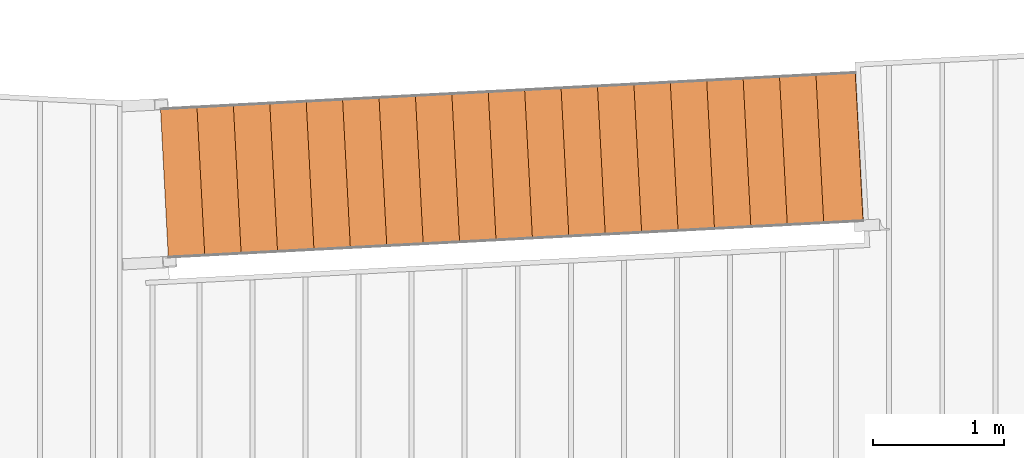
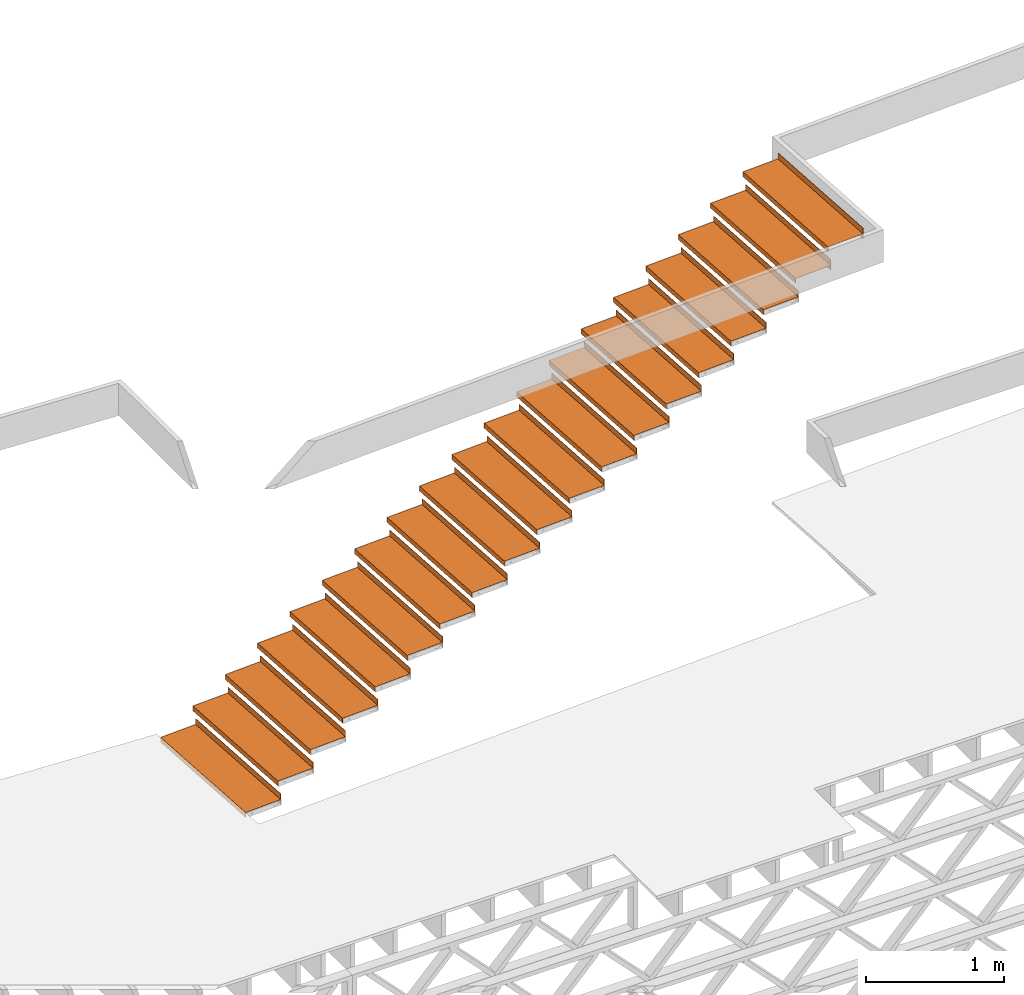
# One storey, part 14 of 23: 19 proxies.
"""IFC4 building model written with IfcOpenShell, lengths in feet."""

from ifc_helpers import new_model, entity, si_unit, converted_unit, derived_unit, direction, frame, origin, place, context, subcontext, project, spatial, polyline, outline, extrude, source, transform, mapped, material, type_object, type_shapes, element, save


model = new_model("IFC4")

# Units and contexts
model_context = context("Model", 3, precision=0.0001, world=origin(), true_north=direction((6.12303176911189e-17, 1.0)))
body_context = subcontext(model_context, "Body", "Model", "MODEL_VIEW")
ifc_project = project(units=[converted_unit("LENGTHUNIT", "FOOT", entity("IfcRatioMeasure", 0.3048), si_unit("LENGTHUNIT", "METRE"), dimensions=[1, 0, 0, 0, 0, 0, 0]), converted_unit("AREAUNIT", "SQUARE FOOT", entity("IfcRatioMeasure", 0.09290304), si_unit("AREAUNIT", "SQUARE_METRE"), dimensions=[2, 0, 0, 0, 0, 0, 0]), converted_unit("VOLUMEUNIT", "CUBIC FOOT", entity("IfcRatioMeasure", 0.028316846592), si_unit("VOLUMEUNIT", "CUBIC_METRE"), dimensions=[3, 0, 0, 0, 0, 0, 0]), converted_unit("PLANEANGLEUNIT", "DEGREE", entity("IfcRatioMeasure", 0.0174532925199433), si_unit("PLANEANGLEUNIT", "RADIAN"), dimensions=[0, 0, 0, 0, 0, 0, 0]), si_unit("MASSUNIT", "GRAM", prefix="KILO"), derived_unit("MASSDENSITYUNIT", [(si_unit("MASSUNIT", "GRAM", prefix="KILO"), 1), (si_unit("LENGTHUNIT", "METRE"), -3)]), derived_unit("MOMENTOFINERTIAUNIT", [(si_unit("LENGTHUNIT", "METRE"), 4)]), si_unit("TIMEUNIT", "SECOND"), si_unit("FREQUENCYUNIT", "HERTZ"), si_unit("THERMODYNAMICTEMPERATUREUNIT", "DEGREE_CELSIUS"), derived_unit("THERMALTRANSMITTANCEUNIT", [(si_unit("MASSUNIT", "GRAM", prefix="KILO"), 1), (si_unit("THERMODYNAMICTEMPERATUREUNIT", "KELVIN"), -1), (si_unit("TIMEUNIT", "SECOND"), -3)]), derived_unit("VOLUMETRICFLOWRATEUNIT", [(si_unit("LENGTHUNIT", "METRE"), 3), (si_unit("TIMEUNIT", "SECOND"), -1)]), si_unit("ELECTRICCURRENTUNIT", "AMPERE"), si_unit("ELECTRICVOLTAGEUNIT", "VOLT"), si_unit("POWERUNIT", "WATT"), si_unit("FORCEUNIT", "NEWTON"), si_unit("ILLUMINANCEUNIT", "LUX"), si_unit("LUMINOUSFLUXUNIT", "LUMEN"), si_unit("LUMINOUSINTENSITYUNIT", "CANDELA"), derived_unit("USERDEFINED", [(si_unit("MASSUNIT", "GRAM", prefix="KILO"), -1), (si_unit("LENGTHUNIT", "METRE"), -2), (si_unit("TIMEUNIT", "SECOND"), 3), (si_unit("LUMINOUSFLUXUNIT", "LUMEN"), 1)]), derived_unit("LINEARVELOCITYUNIT", [(si_unit("LENGTHUNIT", "METRE"), 1), (si_unit("TIMEUNIT", "SECOND"), -1)]), si_unit("PRESSUREUNIT", "PASCAL"), derived_unit("USERDEFINED", [(si_unit("LENGTHUNIT", "METRE"), -2), (si_unit("MASSUNIT", "GRAM", prefix="KILO"), 1), (si_unit("TIMEUNIT", "SECOND"), -2)]), derived_unit("LINEARFORCEUNIT", [(si_unit("MASSUNIT", "GRAM", prefix="KILO"), 1), (si_unit("LENGTHUNIT", "METRE"), 1), (si_unit("TIMEUNIT", "SECOND"), -2), (si_unit("LENGTHUNIT", "METRE"), -1)]), derived_unit("PLANARFORCEUNIT", [(si_unit("MASSUNIT", "GRAM", prefix="KILO"), 1), (si_unit("LENGTHUNIT", "METRE"), 1), (si_unit("TIMEUNIT", "SECOND"), -2), (si_unit("LENGTHUNIT", "METRE"), -2)])], contexts=[model_context])

# Site, building, storey
site_placement = place(None, origin())
site = spatial("IfcSite", under=ifc_project, at=site_placement, CompositionType="ELEMENT")
building_placement = place(site_placement, origin())
building = spatial("IfcBuilding", under=site, at=building_placement, CompositionType="ELEMENT")
storey_placement = place(building_placement, frame((0.0, 0.0, 10.8020833333333)))
storey = spatial("IfcBuildingStorey", under=building, at=storey_placement, Name="2ND FLOOR", CompositionType="ELEMENT", Elevation=10.8020833333333)

# Proxies
ifc_material = material(Name="GALV. STEEL TREAD", Category="Materials")
building_element_proxy_type_1 = type_object("IfcBuildingElementProxyType", Name="Generic Models 889:Generic Models 629", PredefinedType="NOTDEFINED", material=ifc_material)
shared_shape_1 = source(origin(), body_context, "Body", "SweptSolid", [
    extrude(outline(polyline([(-0.597916666666609, 0.02708333333333), (-0.597916666666598, -0.118750000000006), (-0.587499999999985, -0.118750000000006), (-0.587499999999975, 0.0166666666666657), (0.391666666666639, 0.0166666666666657), (0.39166666666665, -0.118750000000006), (0.402083333333319, -0.118750000000006), (0.40208333333334, 0.193750000000001), (0.391666666666621, 0.193750000000001), (0.391666666666639, 0.02708333333333), (-0.597916666666609, 0.02708333333333)])), frame((0.791176413725196, 0.0312925405038413, 0.118750000000006), z_axis=(0.0523359562429694, -0.998629534754573, 0.0), x_axis=(0.998629534754573, 0.0523359562429694, 0.0)), (0.0, 0.0, -1.0), 3.70833333337879),
])
type_shapes(building_element_proxy_type_1, [shared_shape_1])
proxy_1_placement = place(storey_placement, frame((-229.796644235969, 965.360707740668, 6.41392543859246)))
element("IfcBuildingElementProxy", 1, at=proxy_1_placement, inside=storey, type_object=building_element_proxy_type_1, material=ifc_material, Name="Generic Models 889:Generic Models 629", ObjectType="Generic Models 889:Generic Models 629", PredefinedType="NOTDEFINED", context=body_context, shape_type="MappedRepresentation", body=[
    mapped(shared_shape_1, transform((0.0, 0.0, 0.0), scale=1.0)),
])
building_element_proxy_type_2 = type_object("IfcBuildingElementProxyType", Name="Generic Models 891:Generic Models 629", PredefinedType="NOTDEFINED", material=ifc_material)
shared_shape_2 = source(origin(), body_context, "Body", "SweptSolid", [
    extrude(outline(polyline([(-0.597916666666609, 0.02708333333333), (-0.597916666666598, -0.118750000000006), (-0.587499999999957, -0.118750000000006), (-0.587499999999975, 0.0166666666666657), (0.391666666666639, 0.0166666666666657), (0.39166666666665, -0.118750000000006), (0.402083333333348, -0.118750000000006), (0.40208333333334, 0.193750000000001), (0.391666666666621, 0.193750000000001), (0.391666666666639, 0.02708333333333), (-0.597916666666609, 0.02708333333333)])), frame((0.791176413725196, 0.0312925405037277, 0.118750000000006), z_axis=(0.0523359562429694, -0.998629534754573, 0.0), x_axis=(0.998629534754573, 0.0523359562429694, 0.0)), (0.0, 0.0, -1.0), 3.70833333337879),
])
type_shapes(building_element_proxy_type_2, [shared_shape_2])
proxy_2_placement = place(storey_placement, frame((-224.307413781718, 965.648386118748, 9.7823464912242)))
element("IfcBuildingElementProxy", 2, at=proxy_2_placement, inside=storey, type_object=building_element_proxy_type_2, material=ifc_material, Name="Generic Models 891:Generic Models 629", ObjectType="Generic Models 891:Generic Models 629", PredefinedType="NOTDEFINED", context=body_context, shape_type="MappedRepresentation", body=[
    mapped(shared_shape_2, transform((0.0, 0.0, 0.0), scale=1.0)),
])
building_element_proxy_type_3 = type_object("IfcBuildingElementProxyType", Name="Generic Models 893:Generic Models 629", PredefinedType="NOTDEFINED", material=ifc_material)
shared_shape_3 = source(origin(), body_context, "Body", "SweptSolid", [
    extrude(outline(polyline([(-0.597916666666609, 0.02708333333333), (-0.597916666666598, -0.118750000000006), (-0.587499999999985, -0.118750000000006), (-0.587499999999975, 0.0166666666666657), (0.391666666666639, 0.0166666666666657), (0.39166666666665, -0.118750000000006), (0.402083333333319, -0.118750000000006), (0.40208333333334, 0.193750000000001), (0.391666666666621, 0.193750000000001), (0.391666666666639, 0.02708333333333), (-0.597916666666609, 0.02708333333333)])), frame((0.791176413725196, 0.031292540503955, 0.118750000000006), z_axis=(0.0523359562429694, -0.998629534754573, 0.0), x_axis=(0.998629534754573, 0.0523359562429694, 0.0)), (0.0, 0.0, -1.0), 3.70833333337879),
])
type_shapes(building_element_proxy_type_3, [shared_shape_3])
proxy_3_placement = place(storey_placement, frame((-225.222285524093, 965.600439722401, 9.22094298245225)))
element("IfcBuildingElementProxy", 3, at=proxy_3_placement, inside=storey, type_object=building_element_proxy_type_3, material=ifc_material, Name="Generic Models 893:Generic Models 629", ObjectType="Generic Models 893:Generic Models 629", PredefinedType="NOTDEFINED", context=body_context, shape_type="MappedRepresentation", body=[
    mapped(shared_shape_3, transform((0.0, 0.0, 0.0), scale=1.0)),
])
building_element_proxy_type_4 = type_object("IfcBuildingElementProxyType", Name="Generic Models 895:Generic Models 629", PredefinedType="NOTDEFINED", material=ifc_material)
shared_shape_4 = source(origin(), body_context, "Body", "SweptSolid", [
    extrude(outline(polyline([(-0.597916666666609, 0.0270833333333336), (-0.597916666666598, -0.118750000000002), (-0.587499999999957, -0.118750000000002), (-0.587499999999975, 0.0166666666666693), (0.391666666666639, 0.0166666666666693), (0.39166666666665, -0.118750000000002), (0.402083333333348, -0.118750000000002), (0.40208333333334, 0.193750000000005), (0.391666666666621, 0.193750000000005), (0.391666666666639, 0.0270833333333336), (-0.597916666666609, 0.0270833333333336)])), frame((0.791176413725196, 0.0312925405037277, 0.118750000000002), z_axis=(0.0523359562429694, -0.998629534754573, 0.0), x_axis=(0.998629534754573, 0.0523359562429694, 0.0)), (0.0, 0.0, -1.0), 3.70833333337879),
])
type_shapes(building_element_proxy_type_4, [shared_shape_4])
proxy_4_placement = place(storey_placement, frame((-226.137157266468, 965.552493326055, 8.65953947368029)))
element("IfcBuildingElementProxy", 4, at=proxy_4_placement, inside=storey, type_object=building_element_proxy_type_4, material=ifc_material, Name="Generic Models 895:Generic Models 629", ObjectType="Generic Models 895:Generic Models 629", PredefinedType="NOTDEFINED", context=body_context, shape_type="MappedRepresentation", body=[
    mapped(shared_shape_4, transform((0.0, 0.0, 0.0), scale=1.0)),
])
building_element_proxy_type_5 = type_object("IfcBuildingElementProxyType", Name="Generic Models 897:Generic Models 629", PredefinedType="NOTDEFINED", material=ifc_material)
shared_shape_5 = source(origin(), body_context, "Body", "SweptSolid", [
    extrude(outline(polyline([(-0.597916666666609, 0.0270833333333336), (-0.597916666666598, -0.118750000000002), (-0.587499999999957, -0.118750000000002), (-0.587499999999975, 0.0166666666666693), (0.391666666666639, 0.0166666666666693), (0.39166666666665, -0.118750000000002), (0.402083333333348, -0.118750000000002), (0.40208333333334, 0.193750000000005), (0.391666666666621, 0.193750000000005), (0.391666666666639, 0.0270833333333336), (-0.597916666666609, 0.0270833333333336)])), frame((0.791176413725196, 0.0312925405037277, 0.118750000000002), z_axis=(0.0523359562429694, -0.998629534754573, 0.0), x_axis=(0.998629534754573, 0.0523359562429694, 0.0)), (0.0, 0.0, -1.0), 3.70833333337879),
])
type_shapes(building_element_proxy_type_5, [shared_shape_5])
proxy_5_placement = place(storey_placement, frame((-227.052029008843, 965.504546929708, 8.09813596490834)))
element("IfcBuildingElementProxy", 5, at=proxy_5_placement, inside=storey, type_object=building_element_proxy_type_5, material=ifc_material, Name="Generic Models 897:Generic Models 629", ObjectType="Generic Models 897:Generic Models 629", PredefinedType="NOTDEFINED", context=body_context, shape_type="MappedRepresentation", body=[
    mapped(shared_shape_5, transform((0.0, 0.0, 0.0), scale=1.0)),
])
building_element_proxy_type_6 = type_object("IfcBuildingElementProxyType", Name="Generic Models 899:Generic Models 629", PredefinedType="NOTDEFINED", material=ifc_material)
shared_shape_6 = source(origin(), body_context, "Body", "SweptSolid", [
    extrude(outline(polyline([(-0.597916666666609, 0.0270833333333336), (-0.597916666666598, -0.118750000000002), (-0.587499999999957, -0.118750000000002), (-0.587499999999975, 0.0166666666666693), (0.391666666666639, 0.0166666666666693), (0.39166666666665, -0.118750000000002), (0.402083333333348, -0.118750000000002), (0.40208333333334, 0.193750000000005), (0.391666666666621, 0.193750000000005), (0.391666666666639, 0.0270833333333336), (-0.597916666666609, 0.0270833333333336)])), frame((0.791176413725196, 0.031292540503614, 0.118750000000002), z_axis=(0.0523359562429694, -0.998629534754573, 0.0), x_axis=(0.998629534754573, 0.0523359562429694, 0.0)), (0.0, 0.0, -1.0), 3.70833333337879),
])
type_shapes(building_element_proxy_type_6, [shared_shape_6])
proxy_6_placement = place(storey_placement, frame((-227.966900751219, 965.456600533361, 7.53673245613638)))
element("IfcBuildingElementProxy", 6, at=proxy_6_placement, inside=storey, type_object=building_element_proxy_type_6, material=ifc_material, Name="Generic Models 899:Generic Models 629", ObjectType="Generic Models 899:Generic Models 629", PredefinedType="NOTDEFINED", context=body_context, shape_type="MappedRepresentation", body=[
    mapped(shared_shape_6, transform((0.0, 0.0, 0.0), scale=1.0)),
])
building_element_proxy_type_7 = type_object("IfcBuildingElementProxyType", Name="Generic Models 901:Generic Models 629", PredefinedType="NOTDEFINED", material=ifc_material)
shared_shape_7 = source(origin(), body_context, "Body", "SweptSolid", [
    extrude(outline(polyline([(-0.597916666666609, 0.0270833333333336), (-0.597916666666598, -0.118750000000002), (-0.587499999999957, -0.118750000000002), (-0.587499999999975, 0.0166666666666693), (0.391666666666639, 0.0166666666666693), (0.39166666666665, -0.118750000000002), (0.402083333333348, -0.118750000000002), (0.40208333333334, 0.193750000000005), (0.391666666666621, 0.193750000000005), (0.391666666666639, 0.0270833333333336), (-0.597916666666609, 0.0270833333333336)])), frame((0.791176413725196, 0.0312925405038413, 0.118750000000006), z_axis=(0.0523359562429694, -0.998629534754573, 0.0), x_axis=(0.998629534754573, 0.0523359562429694, 0.0)), (0.0, 0.0, -1.0), 3.70833333337879),
])
type_shapes(building_element_proxy_type_7, [shared_shape_7])
proxy_7_placement = place(storey_placement, frame((-228.881772493594, 965.408654137015, 6.97532894736442)))
element("IfcBuildingElementProxy", 7, at=proxy_7_placement, inside=storey, type_object=building_element_proxy_type_7, material=ifc_material, Name="Generic Models 901:Generic Models 629", ObjectType="Generic Models 901:Generic Models 629", PredefinedType="NOTDEFINED", context=body_context, shape_type="MappedRepresentation", body=[
    mapped(shared_shape_7, transform((0.0, 0.0, 0.0), scale=1.0)),
])
building_element_proxy_type_8 = type_object("IfcBuildingElementProxyType", Name="Generic Models 903:Generic Models 629", PredefinedType="NOTDEFINED", material=ifc_material)
shared_shape_8 = source(origin(), body_context, "Body", "SweptSolid", [
    extrude(outline(polyline([(-0.597916666666553, 0.0270833333333336), (-0.597916666666541, -0.118750000000002), (-0.5874999999999, -0.118750000000002), (-0.587499999999918, 0.0166666666666693), (0.391666666666695, 0.0166666666666693), (0.391666666666707, -0.118750000000002), (0.402083333333404, -0.118750000000002), (0.402083333333397, 0.193750000000005), (0.391666666666677, 0.193750000000005), (0.391666666666695, 0.0270833333333336), (-0.597916666666553, 0.0270833333333336)])), frame((0.79117641372514, 0.0312925405037277, 0.118750000000006), z_axis=(0.0523359562429694, -0.998629534754573, 0.0), x_axis=(0.998629534754573, 0.0523359562429694, 0.0)), (0.0, 0.0, -1.0), 3.70833333337879),
])
type_shapes(building_element_proxy_type_8, [shared_shape_8])
proxy_8_placement = place(storey_placement, frame((-230.711515978344, 965.312761344321, 5.8525219298205)))
element("IfcBuildingElementProxy", 8, at=proxy_8_placement, inside=storey, type_object=building_element_proxy_type_8, material=ifc_material, Name="Generic Models 903:Generic Models 629", ObjectType="Generic Models 903:Generic Models 629", PredefinedType="NOTDEFINED", context=body_context, shape_type="MappedRepresentation", body=[
    mapped(shared_shape_8, transform((0.0, 0.0, 0.0), scale=1.0)),
])
building_element_proxy_type_9 = type_object("IfcBuildingElementProxyType", Name="Generic Models 905:Generic Models 629", PredefinedType="NOTDEFINED", material=ifc_material)
shared_shape_9 = source(origin(), body_context, "Body", "SweptSolid", [
    extrude(outline(polyline([(-0.597916666666609, 0.0270833333333336), (-0.597916666666598, -0.118750000000002), (-0.587499999999957, -0.118750000000002), (-0.587499999999975, 0.0166666666666693), (0.391666666666639, 0.0166666666666693), (0.39166666666665, -0.118750000000002), (0.402083333333348, -0.118750000000002), (0.40208333333334, 0.193750000000005), (0.391666666666621, 0.193750000000005), (0.391666666666639, 0.0270833333333336), (-0.597916666666609, 0.0270833333333336)])), frame((0.791176413725196, 0.0312925405037277, 0.118750000000002), z_axis=(0.0523359562429694, -0.998629534754573, 0.0), x_axis=(0.998629534754573, 0.0523359562429694, 0.0)), (0.0, 0.0, -1.0), 3.70833333337879),
])
type_shapes(building_element_proxy_type_9, [shared_shape_9])
proxy_9_placement = place(storey_placement, frame((-231.626387720719, 965.264814947975, 5.29111842104855)))
element("IfcBuildingElementProxy", 9, at=proxy_9_placement, inside=storey, type_object=building_element_proxy_type_9, material=ifc_material, Name="Generic Models 905:Generic Models 629", ObjectType="Generic Models 905:Generic Models 629", PredefinedType="NOTDEFINED", context=body_context, shape_type="MappedRepresentation", body=[
    mapped(shared_shape_9, transform((0.0, 0.0, 0.0), scale=1.0)),
])
building_element_proxy_type_10 = type_object("IfcBuildingElementProxyType", Name="Generic Models 907:Generic Models 629", PredefinedType="NOTDEFINED", material=ifc_material)
shared_shape_10 = source(origin(), body_context, "Body", "SweptSolid", [
    extrude(outline(polyline([(-0.597916666666609, 0.0270833333333318), (-0.597916666666598, -0.118750000000004), (-0.587499999999957, -0.118750000000004), (-0.587499999999975, 0.0166666666666675), (0.391666666666639, 0.0166666666666675), (0.39166666666665, -0.118750000000004), (0.402083333333348, -0.118750000000004), (0.40208333333334, 0.193750000000003), (0.391666666666621, 0.193750000000003), (0.391666666666639, 0.0270833333333318), (-0.597916666666609, 0.0270833333333318)])), frame((0.791176413725196, 0.0312925405037277, 0.118750000000002), z_axis=(0.0523359562429694, -0.998629534754573, 0.0), x_axis=(0.998629534754573, 0.0523359562429694, 0.0)), (0.0, 0.0, -1.0), 3.70833333337879),
])
type_shapes(building_element_proxy_type_10, [shared_shape_10])
proxy_10_placement = place(storey_placement, frame((-232.541259463095, 965.216868551628, 4.7297149122766)))
element("IfcBuildingElementProxy", 10, at=proxy_10_placement, inside=storey, type_object=building_element_proxy_type_10, material=ifc_material, Name="Generic Models 907:Generic Models 629", ObjectType="Generic Models 907:Generic Models 629", PredefinedType="NOTDEFINED", context=body_context, shape_type="MappedRepresentation", body=[
    mapped(shared_shape_10, transform((0.0, 0.0, 0.0), scale=1.0)),
])
building_element_proxy_type_11 = type_object("IfcBuildingElementProxyType", Name="Generic Models 909:Generic Models 629", PredefinedType="NOTDEFINED", material=ifc_material)
shared_shape_11 = source(origin(), body_context, "Body", "SweptSolid", [
    extrude(outline(polyline([(-0.597916666666609, 0.0270833333333318), (-0.597916666666598, -0.118750000000004), (-0.587499999999957, -0.118750000000004), (-0.587499999999975, 0.0166666666666675), (0.391666666666639, 0.0166666666666675), (0.39166666666665, -0.118750000000004), (0.402083333333348, -0.118750000000004), (0.40208333333334, 0.193750000000003), (0.391666666666621, 0.193750000000003), (0.391666666666639, 0.0270833333333318), (-0.597916666666609, 0.0270833333333318)])), frame((0.791176413725196, 0.0312925405037277, 0.118750000000002), z_axis=(0.0523359562429694, -0.998629534754573, 0.0), x_axis=(0.998629534754573, 0.0523359562429694, 0.0)), (0.0, 0.0, -1.0), 3.70833333337879),
])
type_shapes(building_element_proxy_type_11, [shared_shape_11])
proxy_11_placement = place(storey_placement, frame((-233.45613120547, 965.168922155281, 4.16831140350464)))
element("IfcBuildingElementProxy", 11, at=proxy_11_placement, inside=storey, type_object=building_element_proxy_type_11, material=ifc_material, Name="Generic Models 909:Generic Models 629", ObjectType="Generic Models 909:Generic Models 629", PredefinedType="NOTDEFINED", context=body_context, shape_type="MappedRepresentation", body=[
    mapped(shared_shape_11, transform((0.0, 0.0, 0.0), scale=1.0)),
])
building_element_proxy_type_12 = type_object("IfcBuildingElementProxyType", Name="Generic Models 965:Generic Models 629", PredefinedType="NOTDEFINED", material=ifc_material)
shared_shape_12 = source(origin(), body_context, "Body", "SweptSolid", [
    extrude(outline(polyline([(-0.597916666666553, 0.0270833333333336), (-0.597916666666541, -0.118750000000002), (-0.587499999999929, -0.118750000000002), (-0.587499999999918, 0.0166666666666693), (0.391666666666695, 0.0166666666666693), (0.391666666666707, -0.118750000000002), (0.402083333333376, -0.118750000000002), (0.402083333333397, 0.193750000000005), (0.391666666666677, 0.193750000000005), (0.391666666666695, 0.0270833333333336), (-0.597916666666553, 0.0270833333333336)])), frame((0.79117641372514, 0.031292540503955, 0.11875), z_axis=(0.0523359562429694, -0.998629534754573, 0.0), x_axis=(0.998629534754573, 0.0523359562429694, 0.0)), (0.0, 0.0, -1.0), 3.70833333337879),
])
type_shapes(building_element_proxy_type_12, [shared_shape_12])
proxy_12_placement = place(storey_placement, frame((-234.371002947845, 965.120975758934, 3.60690789473269)))
element("IfcBuildingElementProxy", 12, at=proxy_12_placement, inside=storey, type_object=building_element_proxy_type_12, material=ifc_material, Name="Generic Models 965:Generic Models 629", ObjectType="Generic Models 965:Generic Models 629", PredefinedType="NOTDEFINED", context=body_context, shape_type="MappedRepresentation", body=[
    mapped(shared_shape_12, transform((0.0, 0.0, 0.0), scale=1.0)),
])
building_element_proxy_type_13 = type_object("IfcBuildingElementProxyType", Name="Generic Models 911:Generic Models 629", PredefinedType="NOTDEFINED", material=ifc_material)
shared_shape_13 = source(origin(), body_context, "Body", "SweptSolid", [
    extrude(outline(polyline([(-0.597916666666609, 0.0270833333333318), (-0.597916666666598, -0.118750000000004), (-0.587499999999957, -0.118750000000004), (-0.587499999999975, 0.0166666666666675), (0.391666666666639, 0.0166666666666675), (0.39166666666665, -0.118750000000004), (0.402083333333348, -0.118750000000004), (0.40208333333334, 0.193750000000003), (0.391666666666621, 0.193750000000003), (0.391666666666639, 0.0270833333333318), (-0.597916666666609, 0.0270833333333318)])), frame((0.791176413725196, 0.031292540503614, 0.118750000000002), z_axis=(0.0523359562429694, -0.998629534754573, 0.0), x_axis=(0.998629534754573, 0.0523359562429694, 0.0)), (0.0, 0.0, -1.0), 3.70833333337879),
])
type_shapes(building_element_proxy_type_13, [shared_shape_13])
proxy_13_placement = place(storey_placement, frame((-235.28587469022, 965.073029362588, 3.04550438596073)))
element("IfcBuildingElementProxy", 13, at=proxy_13_placement, inside=storey, type_object=building_element_proxy_type_13, material=ifc_material, Name="Generic Models 911:Generic Models 629", ObjectType="Generic Models 911:Generic Models 629", PredefinedType="NOTDEFINED", context=body_context, shape_type="MappedRepresentation", body=[
    mapped(shared_shape_13, transform((0.0, 0.0, 0.0), scale=1.0)),
])
building_element_proxy_type_14 = type_object("IfcBuildingElementProxyType", Name="Generic Models 913:Generic Models 629", PredefinedType="NOTDEFINED", material=ifc_material)
shared_shape_14 = source(origin(), body_context, "Body", "SweptSolid", [
    extrude(outline(polyline([(-0.597916666666609, 0.0270833333333353), (-0.597916666666598, -0.11875), (-0.587499999999957, -0.11875), (-0.587499999999975, 0.016666666666671), (0.391666666666639, 0.016666666666671), (0.39166666666665, -0.11875), (0.402083333333348, -0.11875), (0.40208333333334, 0.193750000000007), (0.391666666666621, 0.193750000000007), (0.391666666666639, 0.0270833333333353), (-0.597916666666609, 0.0270833333333353)])), frame((0.791176413725196, 0.0312925405038413, 0.118749999999999), z_axis=(0.0523359562429694, -0.998629534754573, 0.0), x_axis=(0.998629534754573, 0.0523359562429694, 0.0)), (0.0, 0.0, -1.0), 3.70833333337879),
])
type_shapes(building_element_proxy_type_14, [shared_shape_14])
proxy_14_placement = place(storey_placement, frame((-236.200746432596, 965.025082966241, 2.48410087718877)))
element("IfcBuildingElementProxy", 14, at=proxy_14_placement, inside=storey, type_object=building_element_proxy_type_14, material=ifc_material, Name="Generic Models 913:Generic Models 629", ObjectType="Generic Models 913:Generic Models 629", PredefinedType="NOTDEFINED", context=body_context, shape_type="MappedRepresentation", body=[
    mapped(shared_shape_14, transform((0.0, 0.0, 0.0), scale=1.0)),
])
building_element_proxy_type_15 = type_object("IfcBuildingElementProxyType", Name="Generic Models 915:Generic Models 629", PredefinedType="NOTDEFINED", material=ifc_material)
shared_shape_15 = source(origin(), body_context, "Body", "SweptSolid", [
    extrude(outline(polyline([(-0.597916666666609, 0.02708333333333), (-0.597916666666598, -0.118750000000006), (-0.587499999999957, -0.118750000000006), (-0.587499999999975, 0.0166666666666657), (0.391666666666639, 0.0166666666666657), (0.39166666666665, -0.118750000000006), (0.402083333333348, -0.118750000000006), (0.40208333333334, 0.193750000000001), (0.391666666666621, 0.193750000000001), (0.391666666666639, 0.02708333333333), (-0.597916666666609, 0.02708333333333)])), frame((0.791176413725196, 0.031292540503614, 0.118750000000004), z_axis=(0.0523359562429694, -0.998629534754573, 0.0), x_axis=(0.998629534754573, 0.0523359562429694, 0.0)), (0.0, 0.0, -1.0), 3.70833333337879),
])
type_shapes(building_element_proxy_type_15, [shared_shape_15])
proxy_15_placement = place(storey_placement, frame((-237.115618174971, 964.977136569895, 1.92269736841682)))
element("IfcBuildingElementProxy", 15, at=proxy_15_placement, inside=storey, type_object=building_element_proxy_type_15, material=ifc_material, Name="Generic Models 915:Generic Models 629", ObjectType="Generic Models 915:Generic Models 629", PredefinedType="NOTDEFINED", context=body_context, shape_type="MappedRepresentation", body=[
    mapped(shared_shape_15, transform((0.0, 0.0, 0.0), scale=1.0)),
])
building_element_proxy_type_16 = type_object("IfcBuildingElementProxyType", Name="Generic Models 917:Generic Models 629", PredefinedType="NOTDEFINED", material=ifc_material)
shared_shape_16 = source(origin(), body_context, "Body", "SweptSolid", [
    extrude(outline(polyline([(-0.597916666666553, 0.0270833333333318), (-0.597916666666541, -0.118750000000004), (-0.5874999999999, -0.118750000000004), (-0.587499999999918, 0.0166666666666675), (0.391666666666695, 0.0166666666666675), (0.391666666666707, -0.118750000000004), (0.402083333333404, -0.118750000000004), (0.402083333333397, 0.193750000000003), (0.391666666666677, 0.193750000000003), (0.391666666666695, 0.0270833333333318), (-0.597916666666553, 0.0270833333333318)])), frame((0.79117641372514, 0.0312925405038413, 0.118750000000002), z_axis=(0.0523359562429694, -0.998629534754573, 0.0), x_axis=(0.998629534754573, 0.0523359562429694, 0.0)), (0.0, 0.0, -1.0), 3.70833333337879),
])
type_shapes(building_element_proxy_type_16, [shared_shape_16])
proxy_16_placement = place(storey_placement, frame((-238.030489917346, 964.929190173548, 1.36129385964486)))
element("IfcBuildingElementProxy", 16, at=proxy_16_placement, inside=storey, type_object=building_element_proxy_type_16, material=ifc_material, Name="Generic Models 917:Generic Models 629", ObjectType="Generic Models 917:Generic Models 629", PredefinedType="NOTDEFINED", context=body_context, shape_type="MappedRepresentation", body=[
    mapped(shared_shape_16, transform((0.0, 0.0, 0.0), scale=1.0)),
])
building_element_proxy_type_17 = type_object("IfcBuildingElementProxyType", Name="Generic Models 919:Generic Models 629", PredefinedType="NOTDEFINED", material=ifc_material)
shared_shape_17 = source(origin(), body_context, "Body", "SweptSolid", [
    extrude(outline(polyline([(-0.597916666666609, 0.0270833333333318), (-0.597916666666598, -0.118750000000004), (-0.587499999999957, -0.118750000000004), (-0.587499999999975, 0.0166666666666675), (0.391666666666639, 0.0166666666666675), (0.39166666666665, -0.118750000000004), (0.402083333333348, -0.118750000000004), (0.40208333333334, 0.193750000000003), (0.391666666666621, 0.193750000000003), (0.391666666666639, 0.0270833333333318), (-0.597916666666609, 0.0270833333333318)])), frame((0.791176413725196, 0.0312925405037277, 0.118750000000002), z_axis=(0.0523359562429694, -0.998629534754573, 0.0), x_axis=(0.998629534754573, 0.0523359562429694, 0.0)), (0.0, 0.0, -1.0), 3.70833333337879),
])
type_shapes(building_element_proxy_type_17, [shared_shape_17])
proxy_17_placement = place(storey_placement, frame((-238.945361659721, 964.881243777201, 0.799890350872904)))
element("IfcBuildingElementProxy", 17, at=proxy_17_placement, inside=storey, type_object=building_element_proxy_type_17, material=ifc_material, Name="Generic Models 919:Generic Models 629", ObjectType="Generic Models 919:Generic Models 629", PredefinedType="NOTDEFINED", context=body_context, shape_type="MappedRepresentation", body=[
    mapped(shared_shape_17, transform((0.0, 0.0, 0.0), scale=1.0)),
])
building_element_proxy_type_18 = type_object("IfcBuildingElementProxyType", Name="Generic Models 921:Generic Models 629", PredefinedType="NOTDEFINED", material=ifc_material)
shared_shape_18 = source(origin(), body_context, "Body", "SweptSolid", [
    extrude(outline(polyline([(-0.597916666666609, 0.0270833333333353), (-0.597916666666598, -0.11875), (-0.587499999999985, -0.11875), (-0.587499999999975, 0.016666666666671), (0.391666666666639, 0.016666666666671), (0.39166666666665, -0.11875), (0.402083333333319, -0.11875), (0.40208333333334, 0.193750000000007), (0.391666666666621, 0.193750000000007), (0.391666666666639, 0.0270833333333353), (-0.597916666666609, 0.0270833333333353)])), frame((0.791176413725196, 0.031292540503955, 0.118749999999999), z_axis=(0.0523359562429694, -0.998629534754573, 0.0), x_axis=(0.998629534754573, 0.0523359562429694, 0.0)), (0.0, 0.0, -1.0), 3.70833333337879),
])
type_shapes(building_element_proxy_type_18, [shared_shape_18])
proxy_18_placement = place(storey_placement, frame((-239.860233402096, 964.833297380854, 0.238486842100947)))
element("IfcBuildingElementProxy", 18, at=proxy_18_placement, inside=storey, type_object=building_element_proxy_type_18, material=ifc_material, Name="Generic Models 921:Generic Models 629", ObjectType="Generic Models 921:Generic Models 629", PredefinedType="NOTDEFINED", context=body_context, shape_type="MappedRepresentation", body=[
    mapped(shared_shape_18, transform((0.0, 0.0, 0.0), scale=1.0)),
])
building_element_proxy_type_19 = type_object("IfcBuildingElementProxyType", Name="Generic Models 923:Generic Models 629", PredefinedType="NOTDEFINED", material=ifc_material)
shared_shape_19 = source(origin(), body_context, "Body", "SweptSolid", [
    extrude(outline(polyline([(-0.597916666666609, 0.0270833333333318), (-0.597916666666598, -0.118750000000004), (-0.587499999999957, -0.118750000000004), (-0.587499999999975, 0.0166666666666675), (0.391666666666639, 0.0166666666666675), (0.39166666666665, -0.118750000000004), (0.402083333333348, -0.118750000000004), (0.40208333333334, 0.193750000000003), (0.391666666666621, 0.193750000000003), (0.391666666666639, 0.0270833333333318), (-0.597916666666609, 0.0270833333333318)])), frame((0.791176413725196, 0.0312925405037277, 0.118750000000002), z_axis=(0.0523359562429694, -0.998629534754573, 0.0), x_axis=(0.998629534754573, 0.0523359562429694, 0.0)), (0.0, 0.0, -1.0), 3.70833333337879),
])
type_shapes(building_element_proxy_type_19, [shared_shape_19])
proxy_19_placement = place(storey_placement, frame((-240.775105144472, 964.785350984508, -0.322916666671009)))
element("IfcBuildingElementProxy", 19, at=proxy_19_placement, inside=storey, type_object=building_element_proxy_type_19, material=ifc_material, Name="Generic Models 923:Generic Models 629", ObjectType="Generic Models 923:Generic Models 629", PredefinedType="NOTDEFINED", context=body_context, shape_type="MappedRepresentation", body=[
    mapped(shared_shape_19, transform((0.0, 0.0, 0.0), scale=1.0)),
])

save(model, "model.ifc")
